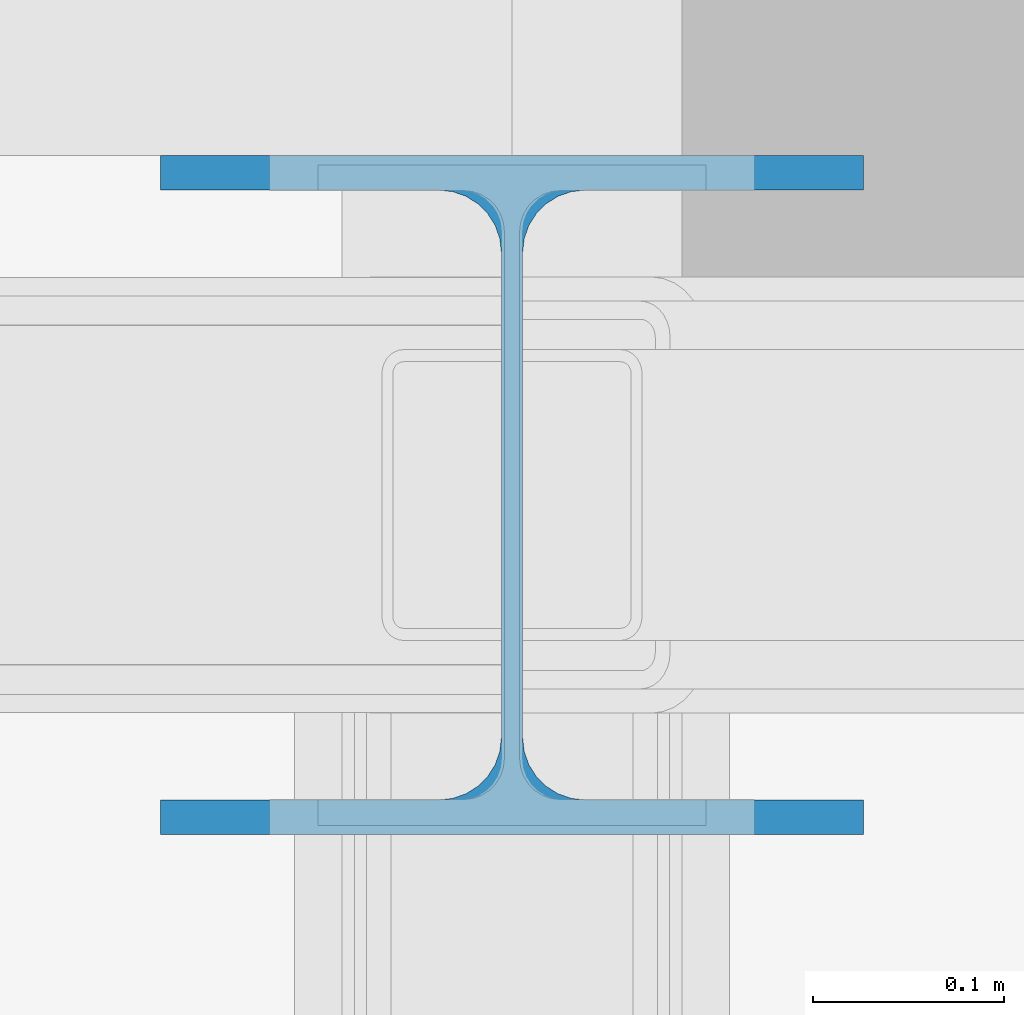
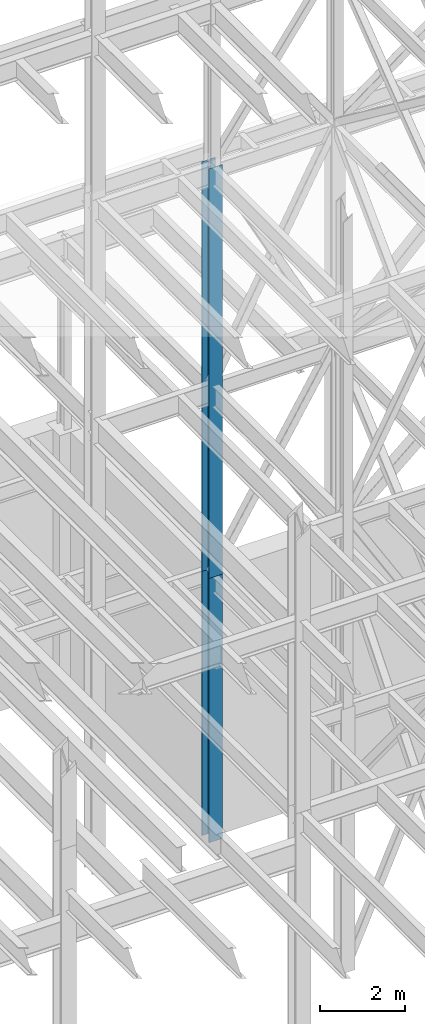
# One storey, part 43 of 150: 2 columns.
"""IFC2X3 building model written with IfcOpenShell, lengths in millimetres."""

from ifc_helpers import new_model, si_unit, frame, origin_with_axes, origin_2d_with_axis, place, context, subcontext, project, spatial, i_section, extrude, material, type_object, element, save


model = new_model("IFC2X3")

# Units and contexts
model_context = context("Model", 3, precision=1e-05, world=origin_with_axes())
body_context = subcontext(model_context, "Body", "Model", "MODEL_VIEW")
ifc_project = project(units=[si_unit("LENGTHUNIT", "METRE", prefix="MILLI"), si_unit("AREAUNIT", "SQUARE_METRE"), si_unit("VOLUMEUNIT", "CUBIC_METRE"), si_unit("MASSUNIT", "GRAM", prefix="KILO"), si_unit("TIMEUNIT", "SECOND"), si_unit("PLANEANGLEUNIT", "RADIAN"), si_unit("SOLIDANGLEUNIT", "STERADIAN"), si_unit("THERMODYNAMICTEMPERATUREUNIT", "DEGREE_CELSIUS"), si_unit("LUMINOUSINTENSITYUNIT", "LUMEN")], contexts=[model_context])

# Site, building, storey
site_placement = place(None, origin_with_axes())
site = spatial("IfcSite", under=ifc_project, at=site_placement, CompositionType="ELEMENT")
building_placement = place(site_placement, origin_with_axes())
building = spatial("IfcBuilding", under=site, at=building_placement, Name="Undefined", CompositionType="ELEMENT")
storey_placement = place(building_placement, origin_with_axes())
storey = spatial("IfcBuildingStorey", under=building, at=storey_placement, Name="Undefined", CompositionType="ELEMENT", Elevation=0.0)

# Columns
ifc_material = material(Name="STEEL/A992")
column_type = type_object("IfcColumnType", Name="W14X90", PredefinedType="NOTDEFINED")
column_1_placement = place(storey_placement, frame((53238.4, 31877.0, 23774.4), z_axis=(0.0, 0.0, 1.0), x_axis=(1.0, 0.0, 0.0)))
element("IfcColumn", 1, at=column_1_placement, inside=storey, type_object=column_type, material=ifc_material, Name="COLUMN", ObjectType="W14X90", context=body_context, shape_type="SweptSolid", body=[
    extrude(i_section(OverallWidth=368.3, OverallDepth=355.6, WebThickness=11.1125, FlangeThickness=18.034, FilletRadius=32.7659, at=origin_2d_with_axis()), frame((0.0, 0.0, 11811.0), z_axis=(0.0, 0.0, -1.0), x_axis=(-1.0, 0.0, 0.0)), (0.0, 0.0, 1.0), 11811.0),
])
column_2_placement = place(storey_placement, frame((53238.4, 31877.0, 16154.4), z_axis=(0.0, 0.0, 1.0), x_axis=(1.0, 0.0, 0.0)))
element("IfcColumn", 2, at=column_2_placement, inside=storey, type_object=column_type, material=ifc_material, Name="COLUMN", ObjectType="W14X90", context=body_context, shape_type="SweptSolid", body=[
    extrude(i_section(OverallWidth=368.3, OverallDepth=355.6, WebThickness=11.1125, FlangeThickness=18.034, FilletRadius=32.7659, at=origin_2d_with_axis()), frame((0.0, 0.0, 7620.0), z_axis=(0.0, 0.0, -1.0), x_axis=(-1.0, 0.0, 0.0)), (0.0, 0.0, 1.0), 7620.0),
])

save(model, "model.ifc")
